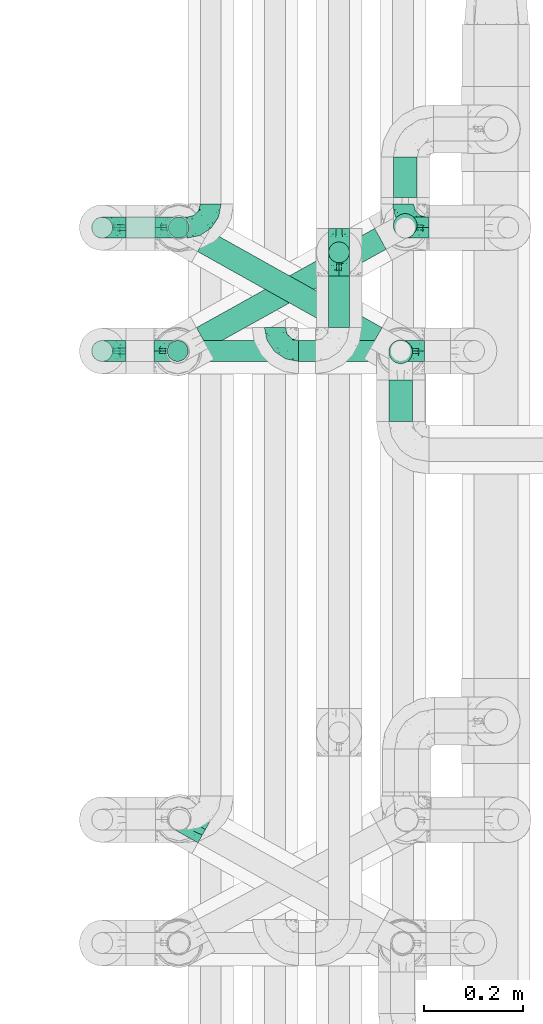
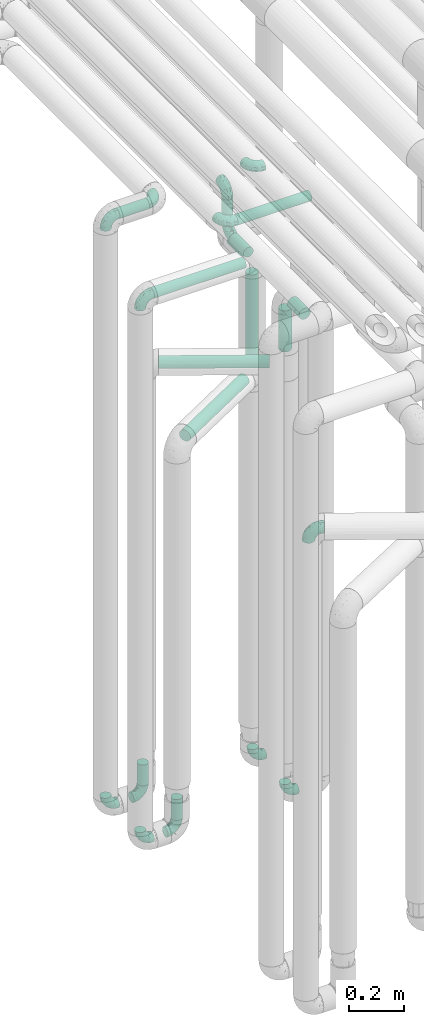
# One storey, part 601 of 827: 14 flow fittings, 13 flow segments.
"""IFC2X3 building model written with IfcOpenShell, lengths in millimetres."""

from ifc_helpers import new_model, entity, si_unit, converted_unit, derived_unit, direction, frame, origin, origin_2d_with_axis, place, context, subcontext, project, spatial, circle, extrude, faceted_brep, source, transform, mapped, material, type_object, type_shapes, element, save


model = new_model("IFC2X3")

# Units and contexts
model_context = context("Model", 3, precision=0.01, world=origin(), true_north=direction((6.12303176911189e-17, 1.0)))
body_context = subcontext(model_context, "Body", "Model", "MODEL_VIEW")
ifc_project = project(units=[si_unit("LENGTHUNIT", "METRE", prefix="MILLI"), si_unit("AREAUNIT", "SQUARE_METRE"), si_unit("VOLUMEUNIT", "CUBIC_METRE"), converted_unit("PLANEANGLEUNIT", "DEGREE", entity("IfcRatioMeasure", 0.0174532925199433), si_unit("PLANEANGLEUNIT", "RADIAN"), dimensions=[0, 0, 0, 0, 0, 0, 0]), si_unit("MASSUNIT", "GRAM", prefix="KILO"), derived_unit("MASSDENSITYUNIT", [(si_unit("MASSUNIT", "GRAM", prefix="KILO"), 1), (si_unit("LENGTHUNIT", "METRE"), -3)]), derived_unit("MOMENTOFINERTIAUNIT", [(si_unit("LENGTHUNIT", "METRE"), 4)]), si_unit("TIMEUNIT", "SECOND"), si_unit("FREQUENCYUNIT", "HERTZ"), si_unit("THERMODYNAMICTEMPERATUREUNIT", "DEGREE_CELSIUS"), derived_unit("THERMALTRANSMITTANCEUNIT", [(si_unit("MASSUNIT", "GRAM", prefix="KILO"), 1), (si_unit("THERMODYNAMICTEMPERATUREUNIT", "KELVIN"), -1), (si_unit("TIMEUNIT", "SECOND"), -3)]), derived_unit("VOLUMETRICFLOWRATEUNIT", [(si_unit("LENGTHUNIT", "METRE"), 3), (si_unit("TIMEUNIT", "SECOND"), -1)]), derived_unit("MASSFLOWRATEUNIT", [(si_unit("MASSUNIT", "GRAM", prefix="KILO"), 1), (si_unit("TIMEUNIT", "SECOND"), -1)]), derived_unit("ROTATIONALFREQUENCYUNIT", [(si_unit("TIMEUNIT", "SECOND"), -1)]), si_unit("ELECTRICCURRENTUNIT", "AMPERE"), si_unit("ELECTRICVOLTAGEUNIT", "VOLT"), si_unit("POWERUNIT", "WATT"), si_unit("FORCEUNIT", "NEWTON", prefix="KILO"), si_unit("ILLUMINANCEUNIT", "LUX"), si_unit("LUMINOUSFLUXUNIT", "LUMEN"), si_unit("LUMINOUSINTENSITYUNIT", "CANDELA"), derived_unit("USERDEFINED", [(si_unit("MASSUNIT", "GRAM", prefix="KILO"), -1), (si_unit("LENGTHUNIT", "METRE"), -2), (si_unit("TIMEUNIT", "SECOND"), 3), (si_unit("LUMINOUSFLUXUNIT", "LUMEN"), 1)]), derived_unit("LINEARVELOCITYUNIT", [(si_unit("LENGTHUNIT", "METRE"), 1), (si_unit("TIMEUNIT", "SECOND"), -1)]), si_unit("PRESSUREUNIT", "PASCAL"), derived_unit("USERDEFINED", [(si_unit("LENGTHUNIT", "METRE"), -2), (si_unit("MASSUNIT", "GRAM", prefix="KILO"), 1), (si_unit("TIMEUNIT", "SECOND"), -2)]), derived_unit("LINEARFORCEUNIT", [(si_unit("MASSUNIT", "GRAM", prefix="KILO"), 1), (si_unit("LENGTHUNIT", "METRE"), 1), (si_unit("TIMEUNIT", "SECOND"), -2), (si_unit("LENGTHUNIT", "METRE"), -1)]), derived_unit("PLANARFORCEUNIT", [(si_unit("MASSUNIT", "GRAM", prefix="KILO"), 1), (si_unit("LENGTHUNIT", "METRE"), 1), (si_unit("TIMEUNIT", "SECOND"), -2), (si_unit("LENGTHUNIT", "METRE"), -2)])], contexts=[model_context])

# Site, building, storey
site_placement = place(None, origin())
site = spatial("IfcSite", under=ifc_project, at=site_placement, CompositionType="ELEMENT")
building_placement = place(site_placement, origin())
building = spatial("IfcBuilding", under=site, at=building_placement, CompositionType="ELEMENT")
storey_placement = place(building_placement, frame((0.0, 0.0, 28200.0)))
storey = spatial("IfcBuildingStorey", under=building, at=storey_placement, Name="08", CompositionType="ELEMENT", Elevation=28200.0)

# Flow segments
pipe_segment_type = type_object("IfcPipeSegmentType", PredefinedType="NOTDEFINED")
flow_segment_1_placement = place(storey_placement, frame((35168.03, 12983.46, 2977.25)))
element("IfcFlowSegment", 1, at=flow_segment_1_placement, inside=storey, type_object=pipe_segment_type, context=body_context, shape_type="SweptSolid", body=[
    extrude(circle(Radius=21.15, at=origin_2d_with_axis()), frame((0.0, 22.75, 22.75), z_axis=(1.0, 0.0, 0.0), x_axis=(0.0, 1.0, 0.0)), (0.0, 0.0, 1.0), 124.000000000015),
])
for number, where in (
    (2, (35252.6, 12983.46, 448.0)),
    (3, (35250.16, 12733.46, 448.0)),
):
    element("IfcFlowSegment", number, at=place(storey_placement, frame(where)), inside=storey, type_object=pipe_segment_type, context=body_context, shape_type="SweptSolid", body=[
        extrude(circle(Radius=21.15, at=origin_2d_with_axis()), frame((22.75, 22.75, 0.0), z_axis=(0.0, 0.0, 1.0), x_axis=(-1.0, 0.0, 0.0)), (0.0, 0.0, 1.0), 92.0000000000094),
    ])
flow_segment_2_placement = place(storey_placement, frame((35577.35, 12933.43, 2847.61)))
element("IfcFlowSegment", 4, at=flow_segment_2_placement, inside=storey, type_object=pipe_segment_type, context=body_context, shape_type="SweptSolid", body=[
    extrude(circle(Radius=21.15, at=origin_2d_with_axis()), frame((22.75, 22.75, 0.0)), (0.0, 0.0, 1.0), 104.39114387437),
])
flow_segment_3_placement = place(storey_placement, frame((35577.35, 12804.17, 2776.86)))
element("IfcFlowSegment", 5, at=flow_segment_3_placement, inside=storey, type_object=pipe_segment_type, context=body_context, shape_type="SweptSolid", body=[
    extrude(circle(Radius=21.15, at=origin_2d_with_axis()), frame((22.75, 0.0, 22.75), z_axis=(0.0, 1.0, 0.0), x_axis=(-1.0, 0.0, 0.0)), (0.0, 0.0, 1.0), 104.000000000015),
])
flow_segment_4_placement = place(storey_placement, frame((35168.03, 12733.43, 2776.86)))
element("IfcFlowSegment", 6, at=flow_segment_4_placement, inside=storey, type_object=pipe_segment_type, context=body_context, shape_type="SweptSolid", body=[
    extrude(circle(Radius=21.15, at=origin_2d_with_axis()), frame((0.0, 22.77, 22.75), z_axis=(0.999999997789185, -6.64953413086212e-05, 0.0), x_axis=(-6.64953413086212e-05, -0.999999997789185, 0.0)), (0.0, 0.0, 1.0), 384.054259178842),
])
flow_segment_5_placement = place(storey_placement, frame((35518.03, 12733.42, 2977.25)))
element("IfcFlowSegment", 7, at=flow_segment_5_placement, inside=storey, type_object=pipe_segment_type, context=body_context, shape_type="SweptSolid", body=[
    extrude(circle(Radius=21.15, at=origin_2d_with_axis()), frame((0.0, 22.75, 22.75), z_axis=(1.0, 0.0, 0.0), x_axis=(0.0, -1.0, 0.0)), (0.0, 0.0, 1.0), 307.750000000012),
])
flow_segment_6_placement = place(storey_placement, frame((35708.54, 12985.08, 2157.0)))
element("IfcFlowSegment", 8, at=flow_segment_6_placement, inside=storey, type_object=pipe_segment_type, context=body_context, shape_type="SweptSolid", body=[
    extrude(circle(Radius=24.0, at=origin_2d_with_axis()), frame((25.6, 25.6, 0.0), z_axis=(0.0, 0.0, 1.0), x_axis=(-1.0, 0.0, 0.0)), (0.0, 0.0, 1.0), 385.999999999986),
])
flow_segment_7_placement = place(storey_placement, frame((35699.44, 12728.87, 2362.0)))
element("IfcFlowSegment", 9, at=flow_segment_7_placement, inside=storey, type_object=pipe_segment_type, context=body_context, shape_type="SweptSolid", body=[
    extrude(circle(Radius=24.0, at=origin_2d_with_axis()), frame((25.6, 25.6, 0.0), z_axis=(0.0, 0.0, 1.0), x_axis=(-1.0, 0.0, 0.0)), (0.0, 0.0, 1.0), 180.999999999998),
])
flow_segment_8_placement = place(storey_placement, frame((35311.78, 12760.12, 2279.4)))
element("IfcFlowSegment", 10, at=flow_segment_8_placement, inside=storey, type_object=pipe_segment_type, context=body_context, shape_type="SweptSolid", body=[
    extrude(circle(Radius=24.0, at=origin_2d_with_axis()), frame((13.31, 218.58, 25.6), z_axis=(0.872709832917215, -0.488239231862421, 0.0), x_axis=(-0.488239231862421, -0.872709832917215, 0.0)), (0.0, 0.0, 1.0), 401.518720143664),
])
flow_segment_9_placement = place(storey_placement, frame((35309.45, 12759.99, 2074.4)))
element("IfcFlowSegment", 11, at=flow_segment_9_placement, inside=storey, type_object=pipe_segment_type, context=body_context, shape_type="SweptSolid", body=[
    extrude(circle(Radius=24.0, at=origin_2d_with_axis()), frame((13.26, 22.57, 25.6), z_axis=(0.873900740639491, 0.486104408033654, 0.0), x_axis=(0.486104408033654, -0.873900740639491, 0.0)), (0.0, 0.0, 1.0), 413.435297220392),
])
flow_segment_10_placement = place(storey_placement, frame((35708.65, 13067.49, 2574.4)))
element("IfcFlowSegment", 12, at=flow_segment_10_placement, inside=storey, type_object=pipe_segment_type, context=body_context, shape_type="SweptSolid", body=[
    extrude(circle(Radius=24.0, at=origin_2d_with_axis()), frame((25.6, 0.0, 25.6), z_axis=(0.0, 1.0, 0.0), x_axis=(1.0, 0.0, 0.0)), (0.0, 0.0, 1.0), 81.5902938725285),
])
flow_segment_11_placement = place(storey_placement, frame((35699.44, 12613.08, 2574.4)))
element("IfcFlowSegment", 13, at=flow_segment_11_placement, inside=storey, type_object=pipe_segment_type, context=body_context, shape_type="SweptSolid", body=[
    extrude(circle(Radius=24.0, at=origin_2d_with_axis()), frame((25.6, 0.0, 25.6), z_axis=(0.0, 1.0, 0.0), x_axis=(-1.0, 0.0, 0.0)), (0.0, 0.0, 1.0), 84.3822522691478),
])

# Flow fittings
ifc_material = material()
pipe_fitting_type_1 = type_object("IfcPipeFittingType", Name="ADSK_1", PredefinedType="NOTDEFINED", material=ifc_material)
shared_shape_1 = source(origin(), body_context, "Body", "Brep", [
    faceted_brep([(-57.0, 12.07, -20.91), (-57.0, 6.25, -23.33), (-57.0, 0.0, -24.15), (-57.0, -6.25, -23.33), (-57.0, -12.08, -20.91), (-57.0, -17.08, -17.08), (-57.0, -20.91, -12.08), (-57.0, -23.33, -6.25), (-57.0, -24.15, 0.0), (-57.0, -23.33, 6.25), (-57.0, -20.91, 12.07), (-57.0, -17.08, 17.08), (-57.0, -12.08, 20.91), (-57.0, -6.25, 23.33), (-57.0, 0.0, 24.15), (-57.0, 6.25, 23.33), (-57.0, 12.07, 20.91), (-57.0, 17.08, 17.08), (-57.0, 20.91, 12.07), (-57.0, 23.33, 6.25), (-57.0, 24.15, 0.0), (-57.0, 23.33, -6.25), (-57.0, 20.91, -12.08), (-57.0, 17.08, -17.08), (0.0, 57.0, -24.15), (-6.25, 57.0, -23.33), (-12.07, 57.0, -20.91), (-17.08, 57.0, -17.08), (-20.91, 57.0, -12.08), (-23.33, 57.0, -6.25), (-24.15, 57.0, 0.0), (-23.33, 57.0, 6.25), (-20.91, 57.0, 12.07), (-17.08, 57.0, 17.08), (-12.07, 57.0, 20.91), (-6.25, 57.0, 23.33), (0.0, 57.0, 24.15), (6.25, 57.0, 23.33), (12.08, 57.0, 20.91), (17.08, 57.0, 17.08), (20.91, 57.0, 12.07), (23.33, 57.0, 6.25), (24.15, 57.0, 0.0), (23.33, 57.0, -6.25), (20.91, 57.0, -12.08), (17.08, 57.0, -17.08), (12.08, 57.0, -20.91), (6.25, 57.0, -23.33), (14.9, 21.14, 6.17), (13.61, 24.64, 12.48), (6.23, 8.95, 8.98), (-41.47, -21.06, 0.0), (-41.92, -18.38, 13.72), (-24.64, -13.61, 12.48), (-37.37, -13.24, 18.15), (-6.8, -4.93, 8.18), (-21.76, -15.19, 6.22), (-12.78, -9.18, 0.0), (-37.73, -20.51, 7.75), (-7.38, 7.38, 20.24), (-23.37, -4.26, 20.42), (-11.9, -3.19, 15.86), (-42.14, -8.7, 21.82), (13.24, 37.37, 18.15), (9.33, 23.53, 16.85), (4.26, 23.37, 20.42), (2.77, 10.92, 15.55), (-29.46, 0.91, 23.52), (-44.13, 20.56, 15.69), (-39.25, 26.33, 10.88), (-49.02, 22.92, 9.96), (-34.58, 23.87, 17.15), (-15.8, 6.8, 22.81), (-8.67, 20.47, 23.88), (-18.12, 12.9, 24.08), (-48.29, 14.92, 19.65), (-44.06, -2.85, 23.78), (-9.23, 48.95, 22.58), (-3.78, 42.74, 24.07), (-40.34, 4.26, 24.09), (-44.02, 26.14, 5.46), (-44.04, 9.88, 22.74), (-4.95, 16.87, 22.52), (-2.75, 1.43, 12.5), (-25.48, 40.98, 10.71), (20.51, 37.73, 7.75), (18.38, 41.92, 13.72), (8.7, 42.14, 21.82), (-25.95, -17.97, 0.0), (2.85, 44.06, 23.78), (21.06, 41.47, 0.0), (17.97, 25.95, 0.0), (-24.04, -9.27, 17.13), (-33.26, 33.26, 5.86), (-28.55, 40.57, 0.0), (-40.57, 28.55, 0.0), (-25.29, 47.19, 4.06), (-27.01, 31.1, 16.77), (-15.7, 43.95, 19.9), (-20.27, 45.22, 15.61), (-30.53, 31.98, 12.64), (-11.28, 38.33, 22.92), (-9.97, 27.88, 24.09), (-20.15, 30.26, 21.25), (-31.25, 11.75, 23.64), (-28.75, 7.23, 24.15), (-29.53, 18.06, 22.27), (-28.44, 24.21, 20.02), (-37.55, 17.7, 20.26), (-15.88, 29.25, 22.99), (-20.82, 20.82, 23.44), (-0.91, 29.46, 23.52), (-13.5, -7.67, 12.04), (1.49, 1.56, 5.16), (8.86, 10.35, 4.59), (0.38, -0.38, 0.0), (9.18, 12.78, 0.0), (-37.37, -13.24, -18.15), (8.86, 10.35, -4.59), (-45.22, 20.27, -15.61), (-43.95, 15.7, -19.9), (-38.33, 11.28, -22.92), (-48.95, 9.23, -22.58), (-47.19, 25.29, -4.06), (-33.26, 33.26, -5.86), (18.38, 41.92, -13.72), (-30.26, 20.15, -21.25), (2.85, 44.06, -23.78), (-4.26, 40.34, -24.09), (-40.98, 25.48, -10.71), (-41.92, -18.38, -13.72), (9.25, 23.5, -16.92), (4.26, 23.37, -20.42), (13.24, 37.37, -18.15), (-37.73, -20.51, -7.75), (-11.75, 31.25, -23.64), (-7.23, 28.75, -24.15), (-12.9, 18.12, -24.08), (8.7, 42.14, -21.82), (-44.06, -2.85, -23.78), (-6.8, 15.8, -22.81), (-20.47, 8.67, -23.88), (-24.64, -13.61, -12.48), (-42.74, 3.78, -24.07), (-18.06, 29.53, -22.27), (-24.21, 28.44, -20.02), (-27.88, 9.97, -24.09), (-31.1, 27.01, -16.77), (-26.14, 44.02, -5.46), (14.9, 21.14, -6.17), (20.51, 37.73, -7.75), (-9.88, 44.04, -22.74), (-20.56, 44.13, -15.69), (-21.76, -15.19, -6.22), (-13.5, -7.67, -12.04), (-24.14, -9.76, -16.74), (-11.9, -3.19, -15.86), (-14.92, 48.29, -19.65), (-23.37, -4.26, -20.42), (-0.91, 29.46, -23.52), (-26.33, 39.25, -10.88), (-23.87, 34.58, -17.15), (-42.14, -8.7, -21.82), (-22.92, 49.02, -9.96), (13.61, 24.64, -12.48), (-31.98, 30.53, -12.64), (-16.87, 4.95, -22.52), (-17.7, 37.55, -20.26), (-29.25, 15.88, -22.99), (-20.82, 20.82, -23.44), (-29.46, 0.91, -23.52), (-7.38, 7.38, -20.24), (2.77, 10.92, -15.55), (6.23, 8.95, -8.98), (-6.8, -4.93, -8.18), (-2.81, 1.41, -12.54), (1.49, 1.56, -5.16)], [[[0, 1, 2, 3, 4, 5, 6, 7, 8, 9, 10, 11, 12, 13, 14, 15, 16, 17, 18, 19, 20, 21, 22, 23]], [[24, 25, 26, 27, 28, 29, 30, 31, 32, 33, 34, 35, 36, 37, 38, 39, 40, 41, 42, 43, 44, 45, 46, 47]], [[48, 49, 50]], [[9, 8, 51]], [[52, 53, 54]], [[55, 56, 57]], [[10, 58, 52]], [[9, 58, 10]], [[59, 60, 61]], [[54, 12, 11]], [[54, 62, 12]], [[63, 39, 38]], [[64, 65, 66]], [[62, 60, 67]], [[68, 69, 70]], [[71, 69, 68]], [[72, 73, 74]], [[16, 75, 17]], [[13, 76, 14]], [[35, 77, 78]], [[14, 79, 15]], [[17, 68, 18]], [[14, 76, 79]], [[20, 19, 80]], [[70, 19, 18]], [[81, 15, 79]], [[15, 81, 16]], [[73, 72, 82]], [[66, 83, 50]], [[32, 31, 84]], [[85, 86, 49]], [[63, 87, 65]], [[56, 58, 88]], [[36, 89, 37]], [[85, 41, 40]], [[36, 35, 78]], [[90, 41, 85]], [[40, 39, 86]], [[12, 62, 13]], [[86, 85, 40]], [[48, 85, 49]], [[85, 91, 90]], [[87, 38, 37]], [[92, 60, 54]], [[80, 69, 93]], [[93, 94, 95]], [[10, 52, 11]], [[94, 96, 30]], [[97, 98, 99]], [[80, 93, 95]], [[100, 97, 84]], [[99, 98, 33]], [[101, 102, 78]], [[103, 101, 98]], [[96, 31, 30]], [[77, 98, 101]], [[77, 35, 34]], [[34, 33, 98]], [[9, 51, 58]], [[87, 63, 38]], [[104, 105, 74]], [[106, 103, 107]], [[106, 81, 104]], [[75, 68, 17]], [[108, 107, 71]], [[33, 32, 99]], [[109, 103, 110]], [[101, 109, 102]], [[89, 78, 111]], [[53, 52, 58]], [[54, 11, 52]], [[60, 62, 54]], [[88, 58, 51]], [[76, 62, 67]], [[53, 112, 92]], [[60, 59, 72]], [[39, 63, 86]], [[49, 86, 63]], [[89, 87, 37]], [[42, 41, 90]], [[111, 82, 65]], [[111, 65, 87]], [[65, 59, 66]], [[104, 81, 79]], [[75, 81, 108]], [[32, 84, 99]], [[97, 99, 84]], [[98, 97, 103]], [[106, 107, 108]], [[74, 102, 110]], [[111, 78, 102]], [[74, 110, 104]], [[74, 67, 72]], [[61, 92, 112]], [[66, 59, 61]], [[56, 53, 58]], [[66, 50, 49]], [[61, 112, 83]], [[66, 49, 64]], [[78, 89, 36]], [[87, 89, 111]], [[62, 76, 13]], [[79, 76, 67]], [[100, 93, 69]], [[96, 93, 84]], [[55, 113, 50]], [[113, 114, 50]], [[104, 79, 105]], [[106, 104, 110]], [[20, 80, 95]], [[85, 48, 91]], [[115, 114, 113]], [[116, 91, 48]], [[70, 80, 19]], [[93, 96, 94]], [[84, 31, 96]], [[103, 106, 110]], [[81, 106, 108]], [[103, 97, 107]], [[71, 107, 97]], [[71, 97, 100]], [[108, 71, 68]], [[79, 67, 105]], [[67, 74, 105]], [[115, 113, 57]], [[112, 56, 55]], [[56, 88, 57]], [[60, 72, 67]], [[82, 72, 59]], [[65, 82, 59]], [[82, 111, 73]], [[111, 102, 73]], [[102, 74, 73]], [[81, 75, 16]], [[68, 75, 108]], [[68, 70, 18]], [[80, 70, 69]], [[98, 77, 34]], [[78, 77, 101]], [[93, 100, 84]], [[71, 100, 69]], [[102, 109, 110]], [[101, 103, 109]], [[53, 92, 54]], [[61, 60, 92]], [[56, 112, 53]], [[83, 112, 55]], [[50, 83, 55]], [[61, 83, 66]], [[49, 63, 64]], [[65, 64, 63]], [[57, 113, 55]], [[114, 115, 116]], [[116, 48, 114]], [[48, 50, 114]], [[117, 5, 4]], [[116, 115, 118]], [[119, 120, 23]], [[121, 122, 120]], [[95, 123, 20]], [[0, 23, 120]], [[124, 95, 94]], [[125, 45, 44]], [[121, 120, 126]], [[24, 127, 128]], [[22, 21, 129]], [[0, 122, 1]], [[5, 117, 130]], [[131, 132, 133]], [[134, 88, 51]], [[135, 136, 137]], [[6, 5, 130]], [[46, 138, 47]], [[139, 3, 2]], [[140, 141, 137]], [[6, 134, 7]], [[134, 130, 142]], [[143, 2, 1]], [[144, 126, 145]], [[121, 146, 143]], [[147, 120, 119]], [[94, 148, 124]], [[149, 150, 91]], [[30, 29, 148]], [[151, 25, 128]], [[27, 152, 28]], [[134, 153, 88]], [[154, 155, 156]], [[27, 26, 157]], [[151, 26, 25]], [[155, 158, 156]], [[24, 47, 127]], [[1, 122, 143]], [[138, 132, 159]], [[160, 152, 161]], [[24, 128, 25]], [[46, 133, 138]], [[162, 117, 4]], [[148, 160, 124]], [[152, 160, 163]], [[154, 142, 155]], [[45, 125, 133]], [[133, 46, 45]], [[125, 164, 133]], [[51, 7, 134]], [[42, 90, 43]], [[165, 147, 129]], [[153, 134, 142]], [[43, 150, 44]], [[162, 4, 3]], [[141, 140, 166]], [[117, 162, 158]], [[163, 29, 28]], [[43, 90, 150]], [[123, 21, 20]], [[144, 151, 135]], [[157, 152, 27]], [[167, 145, 161]], [[23, 22, 119]], [[168, 126, 169]], [[121, 168, 146]], [[139, 143, 170]], [[142, 130, 117]], [[8, 7, 51]], [[134, 6, 130]], [[139, 162, 3]], [[170, 166, 158]], [[170, 158, 162]], [[158, 171, 156]], [[44, 150, 125]], [[91, 150, 90]], [[164, 125, 150]], [[132, 138, 133]], [[127, 138, 159]], [[131, 164, 172]], [[132, 171, 140]], [[135, 151, 128]], [[157, 151, 167]], [[22, 129, 119]], [[147, 119, 129]], [[120, 147, 126]], [[144, 145, 167]], [[137, 146, 169]], [[170, 143, 146]], [[137, 169, 135]], [[137, 159, 140]], [[171, 172, 156]], [[173, 174, 175]], [[156, 175, 154]], [[174, 57, 153]], [[132, 172, 171]], [[172, 164, 173]], [[143, 139, 2]], [[162, 139, 170]], [[138, 127, 47]], [[128, 127, 159]], [[165, 124, 160]], [[123, 124, 129]], [[149, 173, 164]], [[176, 174, 173]], [[135, 128, 136]], [[144, 135, 169]], [[150, 149, 164]], [[176, 118, 115]], [[149, 91, 116]], [[30, 148, 94]], [[163, 148, 29]], [[124, 123, 95]], [[129, 21, 123]], [[126, 144, 169]], [[151, 144, 167]], [[126, 147, 145]], [[161, 145, 147]], [[161, 147, 165]], [[167, 161, 152]], [[128, 159, 136]], [[159, 137, 136]], [[154, 153, 142]], [[132, 140, 159]], [[174, 176, 57]], [[57, 88, 153]], [[166, 140, 171]], [[158, 166, 171]], [[166, 170, 141]], [[170, 146, 141]], [[146, 137, 141]], [[151, 157, 26]], [[152, 157, 167]], [[152, 163, 28]], [[148, 163, 160]], [[120, 122, 0]], [[143, 122, 121]], [[124, 165, 129]], [[161, 165, 160]], [[146, 168, 169]], [[121, 126, 168]], [[142, 117, 155]], [[158, 155, 117]], [[175, 156, 172]], [[153, 154, 174]], [[173, 175, 172]], [[174, 154, 175]], [[164, 131, 133]], [[172, 132, 131]], [[176, 173, 118]], [[57, 176, 115]], [[173, 149, 118]], [[149, 116, 118]]]),
])
type_shapes(pipe_fitting_type_1, [shared_shape_1])
flow_fitting_1_placement = place(storey_placement, frame((35276.24, 11808.13, 2305.0), z_axis=(-0.488239203591698, -0.872709848733326, 0.0), x_axis=(-0.872709848733326, 0.488239203591698, 0.0)))
element("IfcFlowFitting", 14, at=flow_fitting_1_placement, inside=storey, type_object=pipe_fitting_type_1, material=ifc_material, Name="ADSK_1", ObjectType="ADSK_1", context=body_context, shape_type="MappedRepresentation", body=[
    mapped(shared_shape_1, transform((0.0, 0.0, 0.0), scale=1.0)),
])
pipe_fitting_type_2 = type_object("IfcPipeFittingType", Name="ADSK_1", PredefinedType="NOTDEFINED", material=ifc_material)
shared_shape_2 = source(origin(), body_context, "Body", "Brep", [
    faceted_brep([(-48.0, 10.6, -18.36), (-48.0, 5.49, -20.48), (-48.0, 0.0, -21.2), (-48.0, -5.49, -20.48), (-48.0, -10.6, -18.36), (-48.0, -14.99, -14.99), (-48.0, -18.36, -10.6), (-48.0, -20.48, -5.49), (-48.0, -21.2, 0.0), (-48.0, -20.48, 5.49), (-48.0, -18.36, 10.6), (-48.0, -14.99, 14.99), (-48.0, -10.6, 18.36), (-48.0, -5.49, 20.48), (-48.0, 0.0, 21.2), (-48.0, 5.49, 20.48), (-48.0, 10.6, 18.36), (-48.0, 14.99, 14.99), (-48.0, 18.36, 10.6), (-48.0, 20.48, 5.49), (-48.0, 21.2, 0.0), (-48.0, 20.48, -5.49), (-48.0, 18.36, -10.6), (-48.0, 14.99, -14.99), (0.0, 48.0, -21.2), (-5.49, 48.0, -20.48), (-10.6, 48.0, -18.36), (-14.99, 48.0, -14.99), (-18.36, 48.0, -10.6), (-20.48, 48.0, -5.49), (-21.2, 48.0, 0.0), (-20.48, 48.0, 5.49), (-18.36, 48.0, 10.6), (-14.99, 48.0, 14.99), (-10.6, 48.0, 18.36), (-5.49, 48.0, 20.48), (0.0, 48.0, 21.2), (5.49, 48.0, 20.48), (10.6, 48.0, 18.36), (14.99, 48.0, 14.99), (18.36, 48.0, 10.6), (20.48, 48.0, 5.49), (21.2, 48.0, 0.0), (20.48, 48.0, -5.49), (18.36, 48.0, -10.6), (14.99, 48.0, -14.99), (10.6, 48.0, -18.36), (5.49, 48.0, -20.48), (-35.25, -16.22, 12.01), (-34.76, -18.57, 0.0), (-20.87, -12.37, 10.9), (-31.49, -11.78, 15.9), (-37.0, -2.58, 20.86), (-33.89, 3.62, 21.15), (-31.81, -18.14, 6.76), (-5.78, 5.78, 17.67), (-19.42, -4.1, 17.86), (-9.6, -3.39, 13.73), (-35.44, -7.73, 19.13), (11.78, 31.49, 15.9), (-5.93, -5.46, 6.95), (-18.45, -13.78, 5.46), (-10.29, -8.43, 0.0), (-24.6, 0.55, 20.62), (-37.28, 17.94, 13.81), (-33.38, 22.85, 9.59), (-41.46, 20.06, 8.75), (-29.51, 20.45, 15.16), (-15.04, 10.79, 21.13), (-7.08, 16.98, 20.93), (-8.39, 23.51, 21.15), (-40.86, 13.03, 17.26), (-8.05, 41.26, 19.83), (-3.21, 35.97, 21.14), (8.53, 19.66, 14.74), (4.1, 19.42, 17.86), (-37.72, 22.66, 4.78), (-37.07, 8.58, 19.98), (-13.0, 5.43, 19.97), (-3.78, 13.93, 19.7), (3.02, 8.69, 13.43), (-2.27, -0.05, 10.65), (6.22, 6.99, 7.09), (-22.25, 34.6, 9.45), (18.14, 31.81, 6.76), (16.22, 35.25, 12.01), (12.37, 20.87, 10.9), (7.73, 35.44, 19.13), (-21.52, -15.93, 0.0), (2.58, 37.0, 20.86), (18.57, 34.76, 0.0), (13.78, 18.45, 5.46), (15.93, 21.52, 0.0), (-20.03, -8.54, 14.9), (-28.6, 28.6, 5.16), (-24.79, 34.6, 0.0), (-34.6, 24.79, 0.0), (-22.81, 37.41, 4.68), (-23.36, 26.33, 14.79), (-13.68, 37.05, 17.49), (-17.72, 38.12, 13.73), (-26.25, 27.3, 11.24), (-9.71, 32.34, 20.14), (-17.26, 25.6, 18.71), (-26.33, 9.99, 20.77), (-24.06, 6.05, 21.2), (-25.02, 15.46, 19.56), (-24.3, 20.72, 17.57), (-31.95, 15.23, 17.8), (-13.53, 24.7, 20.21), (-17.6, 17.6, 20.6), (-0.55, 24.6, 20.62), (-11.41, -7.48, 10.43), (0.93, -0.93, 0.0), (8.43, 10.29, 0.0), (-11.41, -7.48, -10.43), (-20.1, -8.84, -14.66), (-9.6, -3.39, -13.73), (7.73, 35.44, -19.13), (4.1, 19.42, -17.86), (-0.55, 24.6, -20.62), (-38.12, 17.72, -13.73), (-37.05, 13.68, -17.49), (-32.34, 9.71, -20.14), (-41.26, 8.05, -19.83), (-37.41, 22.81, -4.68), (-23.51, 8.39, -21.15), (-35.97, 3.21, -21.14), (-28.6, 28.6, -5.16), (-31.81, -18.14, -6.76), (-18.45, -13.78, -5.46), (-25.6, 17.26, -18.71), (-19.42, -4.1, -17.86), (-17.94, 37.28, -13.81), (-22.85, 33.38, -9.59), (-20.06, 41.46, -8.75), (-31.49, -11.78, -15.9), (-35.25, -16.22, -12.01), (8.53, 19.66, -14.74), (11.78, 31.49, -15.9), (-9.99, 26.33, -20.77), (-6.05, 24.06, -21.2), (-10.79, 15.04, -21.13), (-37.0, -2.58, -20.86), (-16.98, 7.08, -20.93), (-5.43, 13.0, -19.97), (-13.93, 3.78, -19.7), (-20.87, -12.37, -10.9), (-26.33, 23.36, -14.79), (-22.66, 37.72, -4.78), (13.78, 18.45, -5.46), (18.14, 31.81, -6.76), (-15.46, 25.02, -19.56), (-20.72, 24.3, -17.57), (16.22, 35.25, -12.01), (-13.03, 40.86, -17.26), (-8.58, 37.07, -19.98), (2.58, 37.0, -20.86), (-3.62, 33.89, -21.15), (-34.6, 22.25, -9.45), (6.22, 6.99, -7.09), (-20.45, 29.51, -15.16), (-35.44, -7.73, -19.13), (12.37, 20.87, -10.9), (-27.3, 26.25, -11.24), (-15.23, 31.95, -17.8), (-24.7, 13.53, -20.21), (-24.6, 0.55, -20.62), (-5.78, 5.78, -17.67), (-17.6, 17.6, -20.6), (3.02, 8.69, -13.43), (-5.93, -5.46, -6.95), (-2.27, -0.05, -10.65)], [[[0, 1, 2, 3, 4, 5, 6, 7, 8, 9, 10, 11, 12, 13, 14, 15, 16, 17, 18, 19, 20, 21, 22, 23]], [[24, 25, 26, 27, 28, 29, 30, 31, 32, 33, 34, 35, 36, 37, 38, 39, 40, 41, 42, 43, 44, 45, 46, 47]], [[10, 48, 11]], [[9, 8, 49]], [[48, 50, 51]], [[14, 52, 53]], [[10, 54, 48]], [[9, 54, 10]], [[55, 56, 57]], [[51, 12, 11]], [[51, 58, 12]], [[59, 39, 38]], [[60, 61, 62]], [[58, 56, 63]], [[64, 65, 66]], [[67, 65, 64]], [[68, 69, 70]], [[16, 71, 17]], [[13, 52, 14]], [[35, 72, 73]], [[14, 53, 15]], [[17, 64, 18]], [[74, 59, 75]], [[20, 19, 76]], [[66, 19, 18]], [[77, 15, 53]], [[15, 77, 16]], [[69, 78, 79]], [[80, 81, 82]], [[32, 31, 83]], [[84, 85, 86]], [[59, 87, 75]], [[61, 54, 88]], [[36, 89, 37]], [[84, 41, 40]], [[36, 35, 73]], [[90, 41, 84]], [[40, 39, 85]], [[12, 58, 13]], [[85, 84, 40]], [[91, 84, 86]], [[84, 92, 90]], [[87, 38, 37]], [[93, 56, 51]], [[65, 94, 76]], [[94, 95, 96]], [[84, 91, 92]], [[95, 97, 30]], [[98, 99, 100]], [[76, 94, 96]], [[101, 98, 83]], [[100, 99, 33]], [[102, 70, 73]], [[103, 102, 99]], [[94, 97, 95]], [[72, 99, 102]], [[72, 35, 34]], [[34, 33, 99]], [[9, 49, 54]], [[87, 59, 38]], [[104, 105, 68]], [[106, 103, 107]], [[106, 77, 104]], [[71, 64, 17]], [[108, 107, 67]], [[33, 32, 100]], [[109, 103, 110]], [[102, 109, 70]], [[89, 73, 111]], [[50, 48, 54]], [[51, 11, 48]], [[56, 58, 51]], [[88, 54, 49]], [[52, 58, 63]], [[50, 112, 93]], [[56, 55, 78]], [[39, 59, 85]], [[86, 85, 59]], [[89, 87, 37]], [[42, 41, 90]], [[111, 79, 75]], [[111, 75, 87]], [[75, 55, 80]], [[104, 77, 53]], [[71, 77, 108]], [[32, 83, 100]], [[98, 100, 83]], [[99, 98, 103]], [[106, 107, 108]], [[68, 70, 110]], [[111, 73, 70]], [[68, 110, 104]], [[68, 63, 78]], [[57, 93, 112]], [[80, 55, 57]], [[61, 50, 54]], [[80, 82, 86]], [[81, 57, 112]], [[74, 86, 59]], [[60, 113, 82]], [[82, 114, 91]], [[101, 94, 65]], [[97, 94, 83]], [[73, 89, 36]], [[87, 89, 111]], [[58, 52, 13]], [[53, 52, 63]], [[104, 53, 105]], [[106, 104, 110]], [[20, 76, 96]], [[76, 19, 66]], [[103, 106, 110]], [[77, 106, 108]], [[103, 98, 107]], [[67, 107, 98]], [[67, 98, 101]], [[108, 67, 64]], [[53, 63, 105]], [[63, 68, 105]], [[83, 31, 97]], [[30, 97, 31]], [[62, 113, 60]], [[112, 61, 60]], [[61, 88, 62]], [[86, 82, 91]], [[56, 78, 63]], [[114, 82, 113]], [[114, 92, 91]], [[79, 78, 55]], [[75, 79, 55]], [[69, 79, 111]], [[70, 69, 111]], [[78, 69, 68]], [[77, 71, 16]], [[64, 71, 108]], [[64, 66, 18]], [[76, 66, 65]], [[99, 72, 34]], [[73, 72, 102]], [[94, 101, 83]], [[67, 101, 65]], [[75, 80, 74]], [[80, 86, 74]], [[70, 109, 110]], [[102, 103, 109]], [[50, 93, 51]], [[57, 56, 93]], [[61, 112, 50]], [[81, 112, 60]], [[82, 81, 60]], [[80, 57, 81]], [[115, 116, 117]], [[118, 119, 120]], [[121, 122, 23]], [[123, 124, 122]], [[96, 125, 20]], [[123, 126, 127]], [[128, 96, 95]], [[129, 130, 88]], [[123, 122, 131]], [[116, 132, 117]], [[133, 134, 135]], [[0, 124, 1]], [[5, 136, 137]], [[138, 119, 139]], [[129, 88, 49]], [[140, 141, 142]], [[6, 5, 137]], [[46, 118, 47]], [[143, 3, 2]], [[144, 145, 146]], [[6, 129, 7]], [[129, 137, 147]], [[127, 2, 1]], [[148, 122, 121]], [[128, 125, 96]], [[134, 128, 149]], [[95, 149, 128]], [[150, 151, 92]], [[30, 29, 149]], [[152, 131, 153]], [[27, 133, 28]], [[154, 45, 44]], [[136, 5, 4]], [[27, 26, 155]], [[156, 26, 25]], [[24, 157, 158]], [[24, 47, 157]], [[22, 21, 159]], [[160, 150, 114]], [[134, 133, 161]], [[142, 144, 126]], [[46, 139, 118]], [[162, 136, 4]], [[156, 25, 158]], [[1, 124, 127]], [[115, 147, 116]], [[45, 154, 139]], [[139, 46, 45]], [[154, 163, 139]], [[162, 4, 3]], [[42, 90, 43]], [[130, 129, 147]], [[49, 7, 129]], [[43, 151, 44]], [[0, 23, 122]], [[24, 158, 25]], [[136, 162, 132]], [[135, 29, 28]], [[43, 90, 151]], [[164, 148, 159]], [[152, 156, 140]], [[155, 133, 27]], [[165, 153, 161]], [[23, 22, 121]], [[123, 131, 166]], [[123, 166, 126]], [[143, 127, 167]], [[147, 137, 136]], [[8, 7, 49]], [[129, 6, 137]], [[143, 162, 3]], [[167, 146, 132]], [[167, 132, 162]], [[132, 168, 117]], [[44, 151, 154]], [[92, 151, 90]], [[163, 154, 151]], [[119, 118, 139]], [[157, 118, 120]], [[138, 139, 163]], [[119, 168, 145]], [[140, 156, 158]], [[155, 156, 165]], [[22, 159, 121]], [[148, 121, 159]], [[122, 148, 131]], [[152, 153, 165]], [[142, 126, 169]], [[167, 127, 126]], [[142, 169, 140]], [[142, 120, 145]], [[168, 170, 117]], [[160, 171, 172]], [[115, 172, 171]], [[171, 62, 130]], [[119, 170, 168]], [[170, 163, 160]], [[150, 163, 151]], [[113, 171, 160]], [[164, 128, 134]], [[125, 128, 159]], [[127, 143, 2]], [[162, 143, 167]], [[118, 157, 47]], [[158, 157, 120]], [[140, 158, 141]], [[152, 140, 169]], [[30, 149, 95]], [[149, 29, 135]], [[131, 152, 169]], [[156, 152, 165]], [[131, 148, 153]], [[161, 153, 148]], [[161, 148, 164]], [[165, 161, 133]], [[158, 120, 141]], [[120, 142, 141]], [[159, 21, 125]], [[20, 125, 21]], [[115, 130, 147]], [[114, 113, 160]], [[62, 171, 113]], [[62, 88, 130]], [[160, 163, 150]], [[150, 92, 114]], [[119, 145, 120]], [[146, 145, 168]], [[132, 146, 168]], [[144, 146, 167]], [[126, 144, 167]], [[145, 144, 142]], [[156, 155, 26]], [[133, 155, 165]], [[133, 135, 28]], [[149, 135, 134]], [[122, 124, 0]], [[127, 124, 123]], [[128, 164, 159]], [[161, 164, 134]], [[163, 170, 138]], [[170, 119, 138]], [[131, 169, 166]], [[126, 166, 169]], [[147, 136, 116]], [[132, 116, 136]], [[172, 115, 117]], [[130, 115, 171]], [[117, 170, 172]], [[160, 172, 170]]]),
])
type_shapes(pipe_fitting_type_2, [shared_shape_2])
flow_fitting_2_placement = place(storey_placement, frame((35340.03, 13006.2, 3000.0)))
element("IfcFlowFitting", 15, at=flow_fitting_2_placement, inside=storey, type_object=pipe_fitting_type_2, material=ifc_material, Name="ADSK_1", ObjectType="ADSK_1", context=body_context, shape_type="MappedRepresentation", body=[
    mapped(shared_shape_2, transform((0.0, 0.0, 0.0), scale=1.0)),
])
for number, where, z_axis, x_axis, name in (
    (16, (35120.03, 13006.2, 3000.0), (0.0, -1.0, 0.0), (-1.0, 0.0, 0.0), "ADSK_1"),
    (17, (35120.03, 13006.2, 400.0), (0.0, -1.0, 0.0), (0.0, 0.0, -1.0), "ADSK_1"),
    (18, (35275.34, 13006.2, 400.0), (0.0, -1.0, 0.0), (1.0, 0.0, 0.0), "ADSK_1"),
    (19, (35120.03, 12756.2, 400.0), (0.0, -1.0, 0.0), (0.0, 0.0, -1.0), "ADSK_1"),
    (20, (35272.9, 12756.2, 400.0), (0.0, -1.0, 0.0), (1.0, 0.0, 0.0), "ADSK_1"),
    (21, (35600.09, 12956.17, 3000.0), (1.0, 0.0, 0.0), (0.0, -1.0, 0.0), "ADSK_1"),
    (22, (35600.09, 12956.17, 2799.61), (-1.0, 0.0, 0.0), (0.0, 0.0, -1.0), "ADSK_1"),
    (23, (35120.03, 12756.2, 2799.61), (6.64953412912837e-05, 0.999999997789185, 0.0), (0.0, 0.0, 1.0), "ADSK_1"),
    (24, (35470.03, 12756.17, 3000.0), (0.0, 0.0, 1.0), (0.0, -1.0, 0.0), "ADSK_1"),
    (25, (35725.03, 12756.17, 400.0), (0.0, 1.0, 0.0), (-1.0, 0.0, 0.0), "ADSK_1"),
    (26, (35734.14, 13006.2, 400.0), (0.0, 1.0, 0.0), (-1.0, 0.0, 0.0), "ADSK_1"),
    (27, (35730.03, 13006.2, 3000.0), (0.0, 0.0, 1.0), (0.0, -1.0, 0.0), "ADSK_1"),
):
    element("IfcFlowFitting", number, at=place(storey_placement, frame(where, z_axis=z_axis, x_axis=x_axis)), inside=storey, type_object=pipe_fitting_type_2, material=ifc_material, Name=name, ObjectType="ADSK_1", context=body_context, shape_type="MappedRepresentation", body=[
        mapped(shared_shape_2, transform((0.0, 0.0, 0.0), scale=1.0)),
    ])

save(model, "model.ifc")
